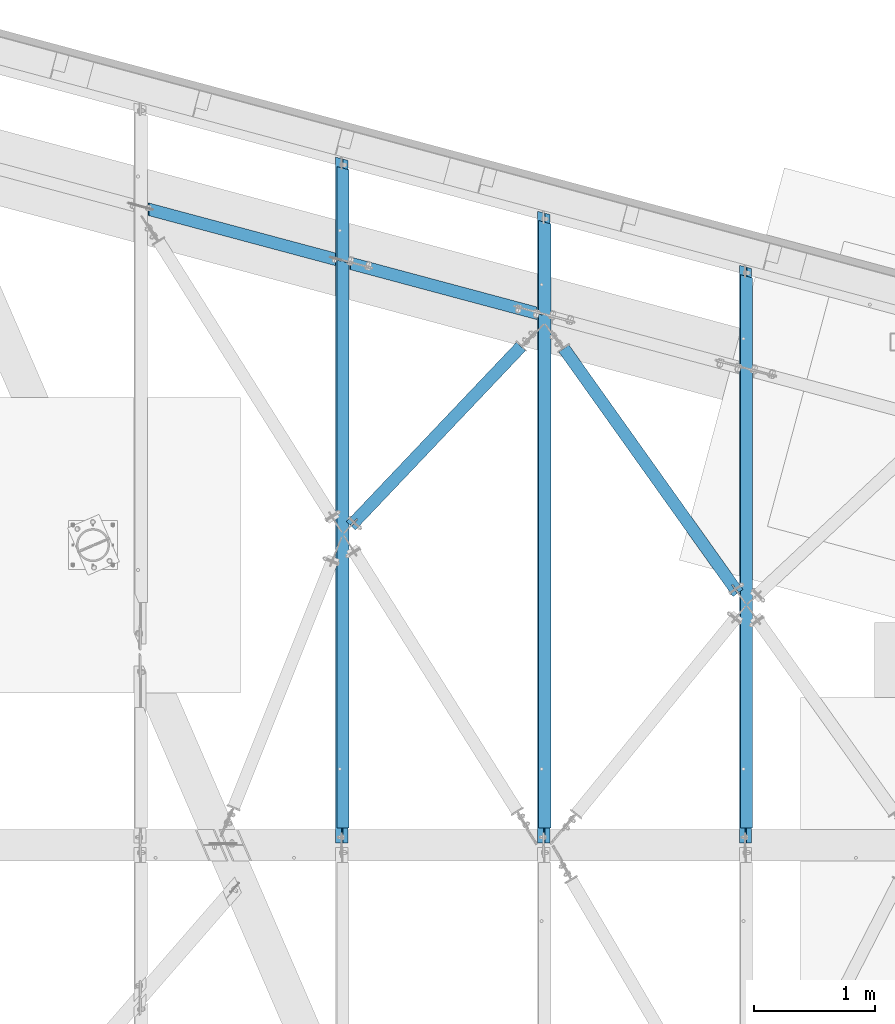
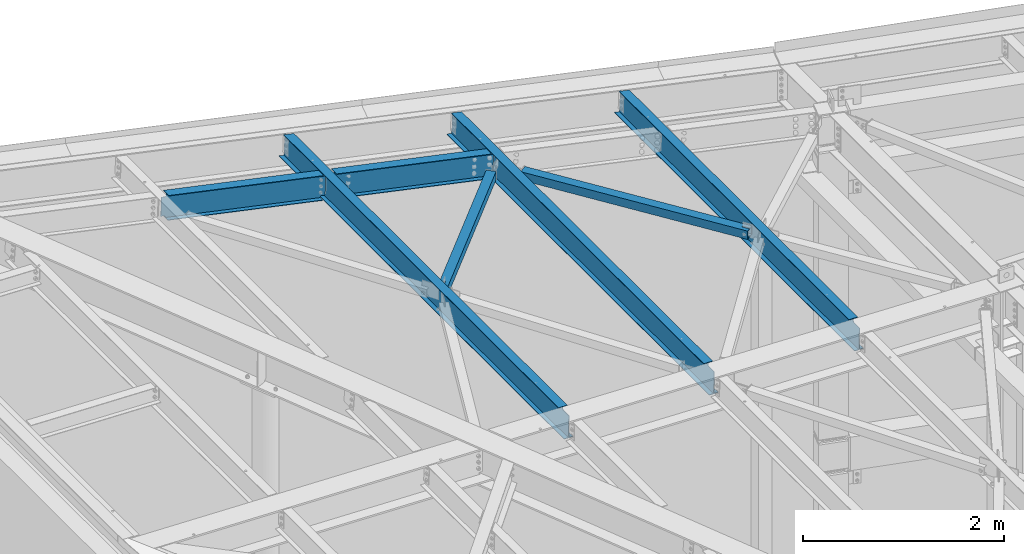
# One storey, part 1157 of 1763: 7 beams, 7 elements without a shape of their own.
"""IFC2X3 building model written with IfcOpenShell, lengths in millimetres."""

from ifc_helpers import new_model, si_unit, frame, origin_with_axes, place, context, subcontext, project, spatial, faceted_brep, material, type_object, element, aggregate, save


model = new_model("IFC2X3")

# Units and contexts
model_context = context("Model", 3, precision=1e-05, world=origin_with_axes())
body_context = subcontext(model_context, "Body", "Model", "MODEL_VIEW")
ifc_project = project(units=[si_unit("LENGTHUNIT", "METRE", prefix="MILLI"), si_unit("AREAUNIT", "SQUARE_METRE"), si_unit("VOLUMEUNIT", "CUBIC_METRE"), si_unit("MASSUNIT", "GRAM", prefix="KILO"), si_unit("TIMEUNIT", "SECOND"), si_unit("PLANEANGLEUNIT", "RADIAN"), si_unit("SOLIDANGLEUNIT", "STERADIAN"), si_unit("THERMODYNAMICTEMPERATUREUNIT", "DEGREE_CELSIUS"), si_unit("LUMINOUSINTENSITYUNIT", "LUMEN")], contexts=[model_context])

# Site, building, storey
site_placement = place(None, origin_with_axes())
site = spatial("IfcSite", under=ifc_project, at=site_placement, CompositionType="ELEMENT")
building_placement = place(site_placement, origin_with_axes())
building = spatial("IfcBuilding", under=site, at=building_placement, Name="Undefined", CompositionType="ELEMENT")
storey_placement = place(building_placement, origin_with_axes())
storey = spatial("IfcBuildingStorey", under=building, at=storey_placement, Name="Undefined", CompositionType="ELEMENT", Elevation=0.0)

# Assembly, beam
assembly_1_placement = place(storey_placement, origin_with_axes())
assembly_1 = element("IfcElementAssembly", 1, at=assembly_1_placement, inside=storey, Name="H. BRACE", AssemblyPlace="NOTDEFINED", PredefinedType="RIGID_FRAME")
ifc_material_1 = material()
beam_type_1 = type_object("IfcBeamType", Name="HSS4X4X3/8", PredefinedType="NOTDEFINED")
beam_1_placement = place(assembly_1_placement, frame((-44670.2201695923, 65768.4829644201, 12475.765625), z_axis=(0.0, 0.0, 1.0), x_axis=(0.688453576193811, 0.725280410204186, 0.0)))
beam_1 = element("IfcBeam", 2, at=beam_1_placement, type_object=beam_type_1, material=ifc_material_1, Name="H. BRACE", ObjectType="HSS4X4X3/8", context=body_context, shape_type="Brep", body=[
    faceted_brep([(95.0234657675064, 6.35000001829758, 50.7999999999993), (95.0234657675064, 6.35000001829758, 41.2749999999996), (173.141541337514, 6.35000001826847, 41.2749999999996), (173.141541337514, 6.35000001826847, 50.7999999999993), (173.141541337511, -6.34999998167041, 50.7999999999993), (173.141541337511, -6.34999998167041, 41.2749999999996), (95.0234657675064, -6.3499999816413, 41.2749999999996), (95.0234657675064, -6.3499999816413, 50.7999999999993), (95.0234657675064, 6.35000001829758, -41.2749999999996), (95.0234657675064, 6.35000001829758, -50.7999999999993), (173.141541337514, 6.35000001826847, -50.7999999999993), (173.141541337514, 6.35000001826847, -41.2749999999996), (173.141541337511, -6.34999998167041, -41.2749999999996), (173.141541337511, -6.34999998167041, -50.7999999999993), (95.0234657675064, -6.3499999816413, -50.7999999999993), (95.0234657675064, -6.3499999816413, -41.2749999999996), (95.0234657675028, -41.2749999999505, -41.2749999999996), (95.0234657675028, -41.2749999999505, 41.2749999999996), (2135.16198679303, -41.2750000006199, 41.2749999999996), (2135.16198679303, -41.2750000006199, -41.2749999999996), (95.0234657675028, 50.7999999998865, -50.7999999999993), (2135.16198679304, 50.7999999992171, -50.7999999999993), (2135.16198679303, -50.800000000585, -50.7999999999993), (95.0234657675064, -50.7999999999447, -50.7999999999993), (95.0234657675064, -50.7999999999447, 50.7999999999993), (2135.16198679303, -50.800000000585, 50.7999999999993), (95.0234657675064, 41.2749999999069, 41.2749999999996), (2135.16198679304, 41.274999999252, 41.2749999999996), (95.0234657675064, 41.2749999999069, -41.2749999999996), (2135.16198679304, 41.274999999252, -41.2749999999996), (2135.16198679304, 50.7999999992171, 50.7999999999993), (95.0234657675028, 50.7999999998865, 50.7999999999993)], [[[0, 1, 2, 3]], [[4, 5, 6, 7]], [[3, 2, 5, 4]], [[8, 9, 10, 11]], [[12, 13, 14, 15]], [[11, 10, 13, 12]], [[16, 17, 18, 19]], [[9, 20, 21, 22, 23, 14, 13, 10]], [[24, 23, 22, 25]], [[17, 16, 15, 14, 23, 24, 7, 6]], [[1, 26, 27, 18, 17, 6, 5, 2]], [[26, 28, 29, 27]], [[25, 22, 21, 30], [18, 27, 29, 19]], [[20, 31, 30, 21]], [[24, 25, 30, 31, 0, 3, 4, 7]], [[31, 20, 9, 8, 28, 26, 1, 0]], [[16, 19, 29, 28, 8, 11, 12, 15]]]),
])
aggregate(assembly_1, [beam_1])

assembly_2_placement = place(storey_placement, origin_with_axes())
assembly_2 = element("IfcElementAssembly", 3, at=assembly_2_placement, inside=storey, Name="H. BRACE", AssemblyPlace="NOTDEFINED", PredefinedType="RIGID_FRAME")
beam_2_placement = place(assembly_2_placement, frame((-41338.5382217806, 65184.4596804294, 12382.5), z_axis=(0.0, 0.0, 1.0), x_axis=(-0.58011823790282, 0.814532276863555, 0.0)))
beam_2 = element("IfcBeam", 4, at=beam_2_placement, type_object=beam_type_1, material=ifc_material_1, Name="H. BRACE", ObjectType="HSS4X4X3/8", context=body_context, shape_type="Brep", body=[
    faceted_brep([(120.584451745584, 6.35000000057971, 50.7999999999993), (120.584451745584, 6.35000000057971, 41.2749999999996), (204.24745206401, 6.35000000048512, 41.2749999999996), (204.24745206401, 6.35000000048512, 50.7999999999993), (204.247452063995, -6.349999999381, 50.7999999999993), (204.247452063995, -6.349999999381, 41.2749999999996), (120.58445174557, -6.34999999929369, 41.2749999999996), (120.58445174557, -6.34999999929369, 50.7999999999993), (120.584451745584, 6.35000000057971, -41.2749999999996), (120.584451745584, 6.35000000057971, -50.7999999999993), (204.24745206401, 6.35000000048512, -50.7999999999993), (204.24745206401, 6.35000000048512, -41.2749999999996), (204.247452063995, -6.349999999381, -41.2749999999996), (204.247452063995, -6.349999999381, -50.7999999999993), (120.58445174557, -6.34999999929369, -50.7999999999993), (120.58445174557, -6.34999999929369, -41.2749999999996), (120.584451745584, -41.2749999999878, -41.2749999999996), (120.584451745584, -41.2749999999878, 41.2749999999996), (2598.63008476434, -41.2750000025781, 41.2749999999996), (2598.63008476434, -41.2750000025781, -41.2749999999996), (120.58445174557, 50.7999999997037, -50.7999999999993), (2598.63008476434, 50.7999999971134, -50.7999999999993), (2598.63008476433, -50.8000000025431, -50.7999999999993), (120.584451745584, -50.7999999999529, -50.7999999999993), (120.584451745584, -50.7999999999529, 50.7999999999993), (2598.63008476433, -50.8000000025431, 50.7999999999993), (120.584451745584, 41.2749999997386, 41.2749999999996), (2598.63008476433, 41.2749999971484, 41.2749999999996), (120.584451745584, 41.2749999997386, -41.2749999999996), (2598.63008476433, 41.2749999971484, -41.2749999999996), (2598.63008476434, 50.7999999971134, 50.7999999999993), (120.58445174557, 50.7999999997037, 50.7999999999993)], [[[0, 1, 2, 3]], [[4, 5, 6, 7]], [[3, 2, 5, 4]], [[8, 9, 10, 11]], [[12, 13, 14, 15]], [[11, 10, 13, 12]], [[16, 17, 18, 19]], [[9, 20, 21, 22, 23, 14, 13, 10]], [[24, 23, 22, 25]], [[17, 16, 15, 14, 23, 24, 7, 6]], [[1, 26, 27, 18, 17, 6, 5, 2]], [[26, 28, 29, 27]], [[25, 22, 21, 30], [18, 27, 29, 19]], [[20, 31, 30, 21]], [[24, 25, 30, 31, 0, 3, 4, 7]], [[31, 20, 9, 8, 28, 26, 1, 0]], [[16, 19, 29, 28, 8, 11, 12, 15]]]),
])
aggregate(assembly_2, [beam_2])

assembly_3_placement = place(storey_placement, origin_with_axes())
assembly_3 = element("IfcElementAssembly", 5, at=assembly_3_placement, inside=storey, Name="BEAM", AssemblyPlace="NOTDEFINED", PredefinedType="RIGID_FRAME")
ifc_material_2 = material(Name="STEEL/A992")
beam_type_2 = type_object("IfcBeamType", Name="W12X16", PredefinedType="NOTDEFINED")
beam_3_placement = place(assembly_3_placement, frame((-41343.0243154241, 63201.5500000139, 12342.6801043308), z_axis=(0.0294363099980619, 0.0, 0.999566657934176), x_axis=(0.0, 1.0, 0.0)))
beam_3 = element("IfcBeam", 6, at=beam_3_placement, type_object=beam_type_2, material=ifc_material_2, Name="BEAM", ObjectType="W12X16", context=body_context, shape_type="Brep", body=[
    faceted_brep([(18.2562499854539, -3.17500000024302, -146.050000000019), (18.2562499854539, -50.8000000002503, -146.050000000032), (4759.10299074829, -50.8000000002503, -146.050000000032), (4771.85854118044, -3.17500000024302, -146.050000000019), (18.2562499854539, -50.8000000002576, -152.400000000032), (4759.15307596333, -50.8000000002576, -152.400000000032), (18.2562499854539, 50.7999999997628, -152.400000000003), (4786.36491688527, 50.7999999997628, -152.400000000003), (18.2562499854539, 50.7999999997701, -146.050000000005), (4786.31483167023, 50.7999999997701, -146.050000000005), (4709.18153798653, 50.8000000002285, 152.400000000032), (4681.969697154, -50.7999999997919, 152.400000000001), (4682.01978232618, -50.7999999997992, 146.050000000001), (4694.77533271644, -3.17499999979191, 146.050000000014), (4694.91895467212, -3.17499999981374, 127.841029633859), (4696.61969472421, 3.17500000018481, 127.841029633872), (4696.47607276848, 3.17500000022119, 146.050000000019), (4709.23162315872, 50.8000000002212, 146.05000000003), (4695.94832424496, -3.17499999982101, 123.010742351491), (4697.64906429706, 3.17500000017753, 123.010742351506), (4698.80490575649, -3.17499999982829, 118.923386869152), (4700.50564580859, 3.17500000017026, 118.923386869164), (4703.05796526757, -3.17499999983556, 116.195281230091), (4704.75870531966, 3.17500000016298, 116.195281230104), (4708.06619880376, -3.17499999982829, 115.237786945811), (4709.76693885586, 3.17500000017026, 115.237786945825), (4771.49839068692, 3.17500000016298, 115.237786956764), (4769.79765062929, -3.17499999983556, 115.237786956755), (4773.55928123806, 3.17499999977008, -146.050000000016), (18.2562499854539, 3.17499999977008, -146.050000000016), (135.035073591156, -3.17499999984284, 111.24155762233), (135.035073591156, 3.17500000015571, 111.241557622343), (130.17499407311, 3.17500000015571, 110.274827699755), (130.17499407311, -3.17499999984284, 110.274827699743), (139.15525005931, -3.17499999983556, 113.99457152281), (139.15525005931, 3.17500000016298, 113.994571522822), (141.908263959784, -3.17499999982829, 118.114747990965), (141.908263959784, 3.17500000017026, 118.11474799098), (142.874993882375, -3.17499999982829, 122.974827509011), (142.874993882375, 3.17500000017753, 122.974827509026), (18.2562499854539, 3.17500000015571, 110.274827699965), (142.874993882375, 3.17500000022119, 146.050000000019), (142.874993882375, 50.8000000002212, 146.05000000003), (142.874993882375, 50.8000000002285, 152.400000000032), (142.874993882375, -50.7999999997919, 152.400000000001), (142.874993882375, -50.7999999997992, 146.050000000001), (142.874993882375, -3.17499999979191, 146.050000000014), (18.2562499854539, -3.17499999984284, 110.274827699976)], [[[0, 1, 2, 3]], [[1, 4, 5, 2]], [[4, 6, 7, 5]], [[6, 8, 9, 7]], [[10, 11, 12, 13, 14, 15, 16, 17]], [[15, 14, 18, 19]], [[19, 18, 20, 21]], [[21, 20, 22, 23]], [[23, 22, 24, 25]], [[26, 25, 24, 27]], [[3, 2, 5, 7, 9, 28, 26, 27]], [[8, 29, 28, 9]], [[30, 31, 32, 33]], [[34, 35, 31, 30]], [[36, 37, 35, 34]], [[38, 39, 37, 36]], [[16, 15, 19, 21, 23, 25, 26, 28, 29, 40, 32, 31, 35, 37, 39, 41]], [[17, 16, 41, 42]], [[10, 17, 42, 43]], [[11, 10, 43, 44]], [[12, 11, 44, 45]], [[13, 12, 45, 46]], [[44, 43, 42, 41, 39, 38, 46, 45]], [[36, 34, 30, 33, 47, 0, 3, 27, 24, 22, 20, 18, 14, 13, 46, 38]], [[29, 8, 6, 4, 1, 0, 47, 40]], [[33, 32, 40, 47]]]),
])
aggregate(assembly_3, [beam_3])

assembly_4_placement = place(storey_placement, origin_with_axes())
assembly_4 = element("IfcElementAssembly", 7, at=assembly_4_placement, inside=storey, Name="BEAM", AssemblyPlace="NOTDEFINED", PredefinedType="RIGID_FRAME")
beam_4_placement = place(assembly_4_placement, frame((-43008.8652893407, 63201.55, 12391.6941673308), z_axis=(0.0294363099980619, 0.0, 0.999566657934176), x_axis=(0.0, 1.0, 0.0)))
beam_4 = element("IfcBeam", 8, at=beam_4_placement, type_object=beam_type_2, material=ifc_material_2, Name="BEAM", ObjectType="W12X16", context=body_context, shape_type="Brep", body=[
    faceted_brep([(18.2562499854539, -3.17500000024302, -146.050000000019), (18.2562499854539, -50.8000000002503, -146.050000000032), (5205.46373538829, -50.800000000243, -146.050000000032), (5218.21928582045, -3.17500000023574, -146.050000000019), (18.2562499854539, -50.8000000002576, -152.400000000032), (5205.51382060334, -50.8000000002503, -152.400000000032), (18.2562499854539, 50.7999999997628, -152.400000000003), (5232.72566152528, 50.7999999997701, -152.400000000003), (18.2562499854539, 50.7999999997701, -146.050000000005), (5232.67557631023, 50.7999999997846, -146.050000000005), (5155.54227911693, 50.8000000002357, 152.400000000031), (5128.33043828439, -50.7999999997846, 152.400000000003), (5128.38052408173, -50.7999999997919, 146.050000000003), (5141.13607447199, -3.17499999977736, 146.050000000016), (5141.26571359565, -3.17499999980646, 129.614034580436), (5142.96645364775, 3.17500000019209, 129.614034580447), (5142.83681452401, 3.17500000022847, 146.050000000017), (5155.59236491426, 50.8000000002285, 146.05000000003), (5142.29508352275, -3.17499999980646, 124.783747670881), (5143.99582357483, 3.17500000019209, 124.783747670894), (5145.1516651142, -3.17499999982101, 120.696392597998), (5146.8524051663, 3.17500000017753, 120.696392598009), (5149.40472447057, -3.17499999982101, 117.968287269268), (5151.10546452265, 3.17500000017753, 117.968287269281), (5154.41295771778, -3.17499999982101, 117.010793099993), (5156.11369776986, 3.17500000017753, 117.010793100004), (5217.84515085536, 3.17500000017753, 117.010793110947), (5216.14441079773, -3.17499999982101, 117.010793110934), (5219.92002587808, 3.17499999977736, -146.050000000017), (18.2562499854539, 3.17499999977008, -146.050000000016), (135.035073605039, -3.17499999983556, 113.558200780159), (135.035073605039, 3.17500000017753, 113.558200780169), (130.174994086992, 3.17500000017026, 112.591470857582), (130.174994086992, -3.17499999983556, 112.591470857569), (139.155250073192, -3.17499999982829, 116.311214680636), (139.155250073192, 3.17500000017026, 116.311214680647), (141.908263973666, -3.17499999982101, 120.43139114879), (141.908263973666, 3.17500000017753, 120.431391148804), (142.874993896257, -3.17499999982101, 125.29147066684), (142.874993896257, 3.17500000019209, 125.291470666851), (18.2562499993364, 3.17500000017026, 112.591470857791), (142.874993882375, 3.17500000022119, 146.050000000019), (142.874993882375, 50.8000000002212, 146.05000000003), (142.874993882375, 50.8000000002285, 152.400000000032), (142.874993882375, -50.7999999997919, 152.400000000001), (142.874993882375, -50.7999999997992, 146.050000000001), (142.874993882375, -3.17499999979191, 146.050000000014), (18.2562499993364, -3.17499999983556, 112.5914708578)], [[[0, 1, 2, 3]], [[1, 4, 5, 2]], [[4, 6, 7, 5]], [[6, 8, 9, 7]], [[10, 11, 12, 13, 14, 15, 16, 17]], [[15, 14, 18, 19]], [[19, 18, 20, 21]], [[21, 20, 22, 23]], [[23, 22, 24, 25]], [[26, 25, 24, 27]], [[3, 2, 5, 7, 9, 28, 26, 27]], [[8, 29, 28, 9]], [[30, 31, 32, 33]], [[34, 35, 31, 30]], [[36, 37, 35, 34]], [[38, 39, 37, 36]], [[16, 15, 19, 21, 23, 25, 26, 28, 29, 40, 32, 31, 35, 37, 39, 41]], [[17, 16, 41, 42]], [[10, 17, 42, 43]], [[11, 10, 43, 44]], [[12, 11, 44, 45]], [[13, 12, 45, 46]], [[44, 43, 42, 41, 39, 38, 46, 45]], [[36, 34, 30, 33, 47, 0, 3, 27, 24, 22, 20, 18, 14, 13, 46, 38]], [[29, 8, 6, 4, 1, 0, 47, 40]], [[33, 32, 40, 47]]]),
])
aggregate(assembly_4, [beam_4])

assembly_5_placement = place(storey_placement, origin_with_axes())
assembly_5 = element("IfcElementAssembly", 9, at=assembly_5_placement, inside=storey, Name="BEAM", AssemblyPlace="NOTDEFINED", PredefinedType="RIGID_FRAME")
beam_5_placement = place(assembly_5_placement, frame((-44674.7062632474, 63201.5499999663, 12440.7807458869), z_axis=(0.0294363099980619, 0.0, 0.999566657934176), x_axis=(0.0, 1.0, 0.0)))
beam_5 = element("IfcBeam", 10, at=beam_5_placement, type_object=beam_type_2, material=ifc_material_2, Name="BEAM", ObjectType="W12X16", context=body_context, shape_type="Brep", body=[
    faceted_brep([(129.381250223734, -3.17499999983556, 114.040001675201), (129.381250223734, 3.17500000017026, 114.040001675214), (18.2562500330459, 3.17500000017026, 114.040001675416), (18.2562500330459, -3.17499999982829, 114.040001675427), (134.241329741781, -3.17499999982829, 115.006731597789), (134.241329741781, 3.17500000017026, 115.006731597803), (138.361506209934, -3.17499999982101, 117.759745498268), (138.361506209934, 3.17500000017753, 117.759745498282), (141.114520110408, -3.17499999982101, 121.879921966425), (141.114520110408, 3.17500000017753, 121.879921966438), (142.081250032999, -3.17499999981374, 126.740001484472), (142.081250032999, 3.17500000018481, 126.740001484484), (142.081250032999, -50.7999999997846, 152.400000000001), (142.081250032999, 50.8000000002357, 152.400000000031), (142.081250032999, 50.8000000002285, 146.05000000003), (142.081250032999, 3.17500000022119, 146.050000000016), (142.081250032999, -3.17499999978463, 146.050000000014), (142.081250032999, -50.7999999997919, 146.050000000001), (18.2562499854539, -3.17500000024302, -146.050000000019), (18.2562499854539, -50.8000000002503, -146.050000000032), (5651.82448004545, -50.800000000243, -146.050000000032), (5664.58003047761, -3.17500000023574, -146.050000000021), (18.2562499854539, -50.8000000002576, -152.400000000032), (5651.87456526049, -50.8000000002576, -152.400000000034), (18.2562499854539, 50.7999999997628, -152.400000000003), (5679.08640618243, 50.7999999997701, -152.400000000003), (18.2562499854539, 50.7999999997701, -146.050000000005), (5679.03632096739, 50.7999999997846, -146.050000000007), (18.2562499854539, 3.17499999977008, -146.050000000016), (5666.28077053522, 3.17499999977008, -146.050000000017), (5664.19248273737, 3.17500000017753, 118.711317348063), (5662.49174267974, -3.17499999982101, 118.711317348054), (5602.46102917426, 3.17500000017753, 118.711317337125), (5600.76028912218, -3.17499999982101, 118.711317337113), (5597.45279603515, 3.17500000017753, 119.668811463382), (5595.75205598305, -3.17499999982101, 119.668811463367), (5593.19973673663, 3.17500000018481, 122.396916676042), (5591.49899668455, -3.17499999981374, 122.396916676027), (5590.34315511528, 3.17500000018481, 126.484271595788), (5588.6424150632, -3.17499999981374, 126.484271595775), (5589.31378505572, 3.17500000019936, 131.31455836591), (5587.61304500362, -3.17499999980646, 131.314558365899), (5601.90302267609, 50.8000000002357, 152.400000000031), (5574.69118184355, -50.7999999997846, 152.400000000001), (5574.7412678747, -50.7999999997919, 146.050000000001), (5587.49681826494, -3.17499999978463, 146.050000000014), (5589.19755831698, 3.17500000022119, 146.050000000016), (5601.95310870723, 50.8000000002285, 146.05000000003)], [[[0, 1, 2, 3]], [[4, 5, 1, 0]], [[6, 7, 5, 4]], [[8, 9, 7, 6]], [[10, 11, 9, 8]], [[12, 13, 14, 15, 11, 10, 16, 17]], [[18, 19, 20, 21]], [[19, 22, 23, 20]], [[22, 24, 25, 23]], [[24, 26, 27, 25]], [[26, 28, 29, 27]], [[21, 20, 23, 25, 27, 29, 30, 31]], [[30, 32, 33, 31]], [[34, 35, 33, 32]], [[36, 37, 35, 34]], [[38, 39, 37, 36]], [[40, 41, 39, 38]], [[42, 43, 44, 45, 41, 40, 46, 47]], [[44, 43, 12, 17]], [[45, 44, 17, 16]], [[8, 6, 4, 0, 3, 18, 21, 31, 33, 35, 37, 39, 41, 45, 16, 10]], [[28, 26, 24, 22, 19, 18, 3, 2]], [[46, 40, 38, 36, 34, 32, 30, 29, 28, 2, 1, 5, 7, 9, 11, 15]], [[47, 46, 15, 14]], [[42, 47, 14, 13]], [[43, 42, 13, 12]]]),
])
aggregate(assembly_5, [beam_5])

assembly_6_placement = place(storey_placement, origin_with_axes())
assembly_6 = element("IfcElementAssembly", 11, at=assembly_6_placement, inside=storey, Name="BEAM", AssemblyPlace="NOTDEFINED", PredefinedType="RIGID_FRAME")
beam_type_3 = type_object("IfcBeamType", Name="W12X14", PredefinedType="NOTDEFINED")
beam_6_placement = place(assembly_6_placement, frame((-46340.349227482, 68468.1037576152, 12498.4168456985), z_axis=(0.0284332150015107, -0.00761865702657088, 0.99956666028324), x_axis=(0.965507252136511, -0.258706889036504, -0.029436230004148)))
beam_6 = element("IfcBeam", 12, at=beam_6_placement, type_object=beam_type_3, material=ifc_material_2, Name="BEAM", ObjectType="W12X14", context=body_context, shape_type="Brep", body=[
    faceted_brep([(1673.38095559363, -50.7999999977619, 150.812500001273), (1673.37436443758, -50.7999999977619, 144.462500001273), (1660.40661791053, -2.38124999773572, 144.462500001257), (1660.38295755932, -2.38124999776483, 121.667829247368), (1659.10744150749, 2.38125000223954, 121.667829247701), (1659.13110185869, 2.38125000226137, 144.462500001253), (1646.16335533164, 50.8000000023021, 144.462500001233), (1646.16994648769, 50.8000000023021, 150.812500001233), (1661.37997226533, -2.38124999775027, 116.803840761082), (1660.10445621351, 2.38125000223954, 116.803840761409), (1664.22913400518, -2.38124999776483, 112.679342845613), (1662.95361795336, 2.38125000224682, 112.679342845942), (1668.49613696354, -2.38124999775755, 109.923044431367), (1667.22062091173, 2.38125000224682, 109.923044431695), (1673.53054976163, -2.381249997743, 108.955095913221), (1672.25503370981, 2.38125000225409, 108.95509591355), (1708.39776640594, -2.38124999769934, 108.955095918162), (1708.39776643887, 2.38125000230502, 108.955095918682), (79.5559065478592, -50.7999999998356, 150.812500000036), (52.3448974419152, 50.8000000002285, 150.812499999998), (52.3383059591652, 50.8000000002285, 144.462499999998), (65.3060524862303, 2.38125000020227, 144.46250000002), (65.2806888098348, 2.38125000018772, 120.028036849619), (66.5562048616484, -2.38124999982392, 120.028036849291), (66.5815685380658, -2.38124999980209, 144.462500000021), (79.5493150651164, -50.799999999821, 144.46250000004), (64.2761069416592, 2.38125000017317, 115.171869242033), (65.5516229934801, -2.38124999982392, 115.171869241705), (61.4251908362203, 2.38125000016589, 111.056013944048), (62.7007068880412, -2.38124999983847, 111.056013943718), (57.1614198260067, 2.38125000017317, 108.306283200303), (58.4369358778349, -2.3812499998312, 108.306283199976), (52.1330966120149, 2.38125000014406, 107.340771196408), (53.4086126638504, -2.38124999983847, 107.340771196081), (17.2395154830883, 2.38125000011496, 107.340771191408), (17.2395155142658, -2.38124999988941, 107.340771190886), (16.9990052657085, 2.38124999994761, -124.364590106024), (16.9990054505324, -2.38125000004948, -124.364590106547), (51.8662216036537, 2.38124999999854, -124.364590102023), (53.1417376554891, -2.3812500000131, -124.36459010235), (56.9006344564041, 2.38125000000582, -125.33253864204), (58.1761505082177, -2.3812500000131, -125.332538642368), (61.167637443752, 2.38125000000582, -128.088837115254), (62.4431534955729, -2.38124999999854, -128.088837115583), (64.0167991677736, 2.38124999999127, -132.213335108294), (65.2923152196017, -2.38124999999127, -132.213335108623), (65.0138138057737, 2.38124999999854, -137.077323664727), (66.2893298575946, -2.38125000000582, -137.077323665055), (66.281664074093, -2.38124999999854, -144.462499999916), (79.2494106011436, -50.8000000000466, -144.462499999896), (1673.07446033281, -50.7999999979802, -144.462499998661), (1660.10671380576, -2.38124999793945, -144.462499998681), (79.2428193268061, -50.8000000000466, -150.812499999894), (1673.06786860385, -50.7999999979875, -150.812499998661), (52.0318102208475, 50.8000000000175, -150.812499999935), (52.0384014951997, 50.8000000000393, -144.462499999938), (1645.86345122687, 50.8000000020838, -144.462499998701), (1645.85685949791, 50.8000000020766, -150.812499998699), (65.0061480222503, 2.38124999999127, -144.462499999918), (1658.83119775391, 2.38125000205764, -144.462499998683), (1658.84056628166, 2.38125000207219, -135.437530568135), (1660.11608233349, -2.381249997954, -135.437530568463), (1659.84514829094, 2.38125000207219, -130.581363106716), (1661.12066434275, -2.38124999791762, -130.581363107045), (1662.69606442897, 2.38125000207947, -126.465507970128), (1663.97158048079, -2.38124999791034, -126.465507970455), (1666.95983537875, 2.38125000209402, -123.715777348991), (1668.23535143057, -2.3812499979249, -123.71577734932), (1671.988158479, 2.38125000209402, -122.750265390583), (1673.26367453082, -2.38124999791034, -122.75026539091), (1708.15725618855, -2.38124999787397, -122.750265386961), (1708.15725637513, 2.38125000213768, -122.750265386441)], [[[0, 1, 2, 3, 4, 5, 6, 7]], [[8, 9, 4, 3]], [[10, 11, 9, 8]], [[12, 13, 11, 10]], [[14, 15, 13, 12]], [[16, 17, 15, 14]], [[18, 19, 20, 21, 22, 23, 24, 25]], [[23, 22, 26, 27]], [[27, 26, 28, 29]], [[29, 28, 30, 31]], [[31, 30, 32, 33]], [[33, 32, 34, 35]], [[35, 34, 36, 37]], [[37, 36, 38, 39]], [[39, 38, 40, 41]], [[41, 40, 42, 43]], [[43, 42, 44, 45]], [[45, 44, 46, 47]], [[48, 49, 50, 51]], [[49, 52, 53, 50]], [[54, 55, 56, 57]], [[52, 54, 57, 53]], [[49, 48, 47, 46, 58, 55, 54, 52]], [[55, 58, 59, 56]], [[50, 53, 57, 56, 59, 60, 61, 51]], [[61, 60, 62, 63]], [[63, 62, 64, 65]], [[65, 64, 66, 67]], [[67, 66, 68, 69]], [[70, 69, 68, 71]], [[12, 10, 8, 3, 2, 24, 23, 27, 29, 31, 33, 35, 37, 39, 41, 43, 45, 47, 48, 51, 61, 63, 65, 67, 69, 70, 16, 14]], [[25, 24, 2, 1]], [[18, 25, 1, 0]], [[19, 18, 0, 7]], [[20, 19, 7, 6]], [[21, 20, 6, 5]], [[71, 68, 66, 64, 62, 60, 59, 58, 46, 44, 42, 40, 38, 36, 34, 32, 30, 28, 26, 22, 21, 5, 4, 9, 11, 13, 15, 17]], [[70, 71, 17, 16]]]),
])
aggregate(assembly_6, [beam_6])

assembly_7_placement = place(storey_placement, origin_with_axes())
assembly_7 = element("IfcElementAssembly", 13, at=assembly_7_placement, inside=storey, Name="BEAM", AssemblyPlace="NOTDEFINED", PredefinedType="RIGID_FRAME")
beam_7_placement = place(assembly_7_placement, frame((-44674.5082537208, 68021.7430138079, 12447.6289554208), z_axis=(0.0284332150015107, -0.00761865702657088, 0.99956666028324), x_axis=(0.965507252136511, -0.258706889036504, -0.029436230004148)))
beam_7 = element("IfcBeam", 14, at=beam_7_placement, type_object=beam_type_3, material=ifc_material_2, Name="BEAM", ObjectType="W12X14", context=body_context, shape_type="Brep", body=[
    faceted_brep([(1673.32911031006, -50.7999999978056, 150.812500001275), (1673.32251916796, -50.7999999978056, 144.462500001277), (1660.35477264092, -2.3812499977721, 144.462500001255), (1660.3328774938, -2.38124999779393, 123.36840370045), (1659.05736144197, 2.38125000221044, 123.368403700777), (1659.07925658907, 2.38125000223226, 144.462500001255), (1646.11151006203, 50.8000000022585, 144.462500001235), (1646.11810120411, 50.8000000022585, 150.812500001233), (1661.32989220784, -2.38124999779393, 118.504415222436), (1660.05437615602, 2.38125000221044, 118.504415222764), (1664.17905394956, -2.38124999778665, 114.379917316122), (1662.90353789774, 2.38125000221044, 114.37991731645), (1668.4460569045, -2.38124999778665, 111.623618908832), (1667.17054085269, 2.38125000221771, 111.62361890916), (1673.48046969615, -2.3812499977721, 110.655670393269), (1672.20495364432, 2.38125000221771, 110.655670393597), (1708.34768636662, -2.38124999773572, 110.655670398206), (1708.34768639842, 2.38125000227592, 110.655670398726), (79.5038660791033, -50.7999999998574, 150.812500000038), (52.2928569731739, 50.8000000002066, 150.8125), (52.2862656509096, 50.8000000002066, 144.4625), (65.254012177953, 2.38125000016589, 144.462500000021), (65.2304209310023, 2.38125000015134, 121.73497898142), (66.5059369828377, -2.38124999983847, 121.734978981091), (66.529528229803, -2.38124999984575, 144.462500000023), (79.4972747568536, -50.7999999998574, 144.462500000041), (64.2258391548094, 2.38125000015862, 116.878811278553), (65.5013552066303, -2.3812499998603, 116.878811278224), (61.3749230706089, 2.38125000015134, 112.762955875363), (62.6504391224225, -2.38124999985303, 112.762955875036), (57.1111520210034, 2.38125000013679, 110.013225051705), (58.386668072817, -2.38124999986758, 110.013225051378), (52.0828287328695, 2.38125000012951, 109.047713018172), (53.3583447846831, -2.38124999988213, 109.047713017844), (17.1892479310627, 2.38125000008586, 109.047713013228), (17.1892479610979, -2.38124999993306, 109.047713012709), (16.9487377136829, 2.38124999992579, -122.657648281913), (16.9487378973499, -2.3812500000713, -122.657648282433), (51.815953586156, 2.38124999997672, -122.657648277969), (53.0914696379696, -2.38125000002765, -122.657648278297), (56.8503665440585, 2.38124999997672, -123.625596860104), (58.1258825958794, -2.38125000002037, -123.625596860435), (61.1173695871476, 2.38124999996217, -126.381895446819), (62.3928856389684, -2.38125000002037, -126.381895447146), (63.9665312807119, 2.38124999997672, -130.506393589159), (65.2420473325401, -2.3812500000131, -130.506393589487), (64.9635457877739, 2.38124999998399, -135.370382280584), (66.2390618395948, -2.38125000003492, -135.370382280911), (66.2296239317948, -2.38125000003492, -144.462499999914), (79.1973704588454, -50.8000000000611, -144.462499999894), (1673.02261501063, -50.799999998002, -144.462499998661), (1660.05486848357, -2.38124999797583, -144.462499998681), (79.1907789567849, -50.8000000000684, -150.812499999894), (1673.0160232892, -50.7999999980166, -150.812499998658), (51.9797698508482, 50.7999999999884, -150.812499999931), (51.9863613528942, 50.8000000000029, -144.462499999934), (1645.81160590468, 50.800000002062, -144.462499998699), (1645.80501418326, 50.8000000020475, -150.812499998698), (64.9541078799593, 2.38124999996944, -144.462499999916), (1658.77935243174, 2.38125000202854, -144.462499998681), (1658.79048625794, 2.38125000204309, -133.736956102412), (1660.06600230977, -2.38124999796128, -133.736956102739), (1659.79506826291, 2.38125000204309, -128.880788636523), (1661.07058431472, -2.381249997954, -128.88078863685), (1662.64598439995, 2.38125000204309, -124.764933495), (1663.92150045176, -2.381249997954, -124.764933495329), (1666.90975535157, 2.38125000205764, -122.015202870116), (1668.18527140338, -2.38124999794672, -122.015202870443), (1671.9380784553, 2.38125000206492, -121.049690910317), (1673.21359450711, -2.38124999793945, -121.049690910646), (1708.10717614923, -2.38124999789579, -121.049690906697), (1708.10717633468, 2.3812500021013, -121.049690906179)], [[[0, 1, 2, 3, 4, 5, 6, 7]], [[8, 9, 4, 3]], [[10, 11, 9, 8]], [[12, 13, 11, 10]], [[14, 15, 13, 12]], [[16, 17, 15, 14]], [[18, 19, 20, 21, 22, 23, 24, 25]], [[23, 22, 26, 27]], [[27, 26, 28, 29]], [[29, 28, 30, 31]], [[31, 30, 32, 33]], [[33, 32, 34, 35]], [[35, 34, 36, 37]], [[37, 36, 38, 39]], [[39, 38, 40, 41]], [[41, 40, 42, 43]], [[43, 42, 44, 45]], [[45, 44, 46, 47]], [[48, 49, 50, 51]], [[49, 52, 53, 50]], [[54, 55, 56, 57]], [[52, 54, 57, 53]], [[49, 48, 47, 46, 58, 55, 54, 52]], [[55, 58, 59, 56]], [[50, 53, 57, 56, 59, 60, 61, 51]], [[61, 60, 62, 63]], [[63, 62, 64, 65]], [[65, 64, 66, 67]], [[67, 66, 68, 69]], [[70, 69, 68, 71]], [[12, 10, 8, 3, 2, 24, 23, 27, 29, 31, 33, 35, 37, 39, 41, 43, 45, 47, 48, 51, 61, 63, 65, 67, 69, 70, 16, 14]], [[25, 24, 2, 1]], [[18, 25, 1, 0]], [[19, 18, 0, 7]], [[20, 19, 7, 6]], [[21, 20, 6, 5]], [[71, 68, 66, 64, 62, 60, 59, 58, 46, 44, 42, 40, 38, 36, 34, 32, 30, 28, 26, 22, 21, 5, 4, 9, 11, 13, 15, 17]], [[70, 71, 17, 16]]]),
])
aggregate(assembly_7, [beam_7])

save(model, "model.ifc")
